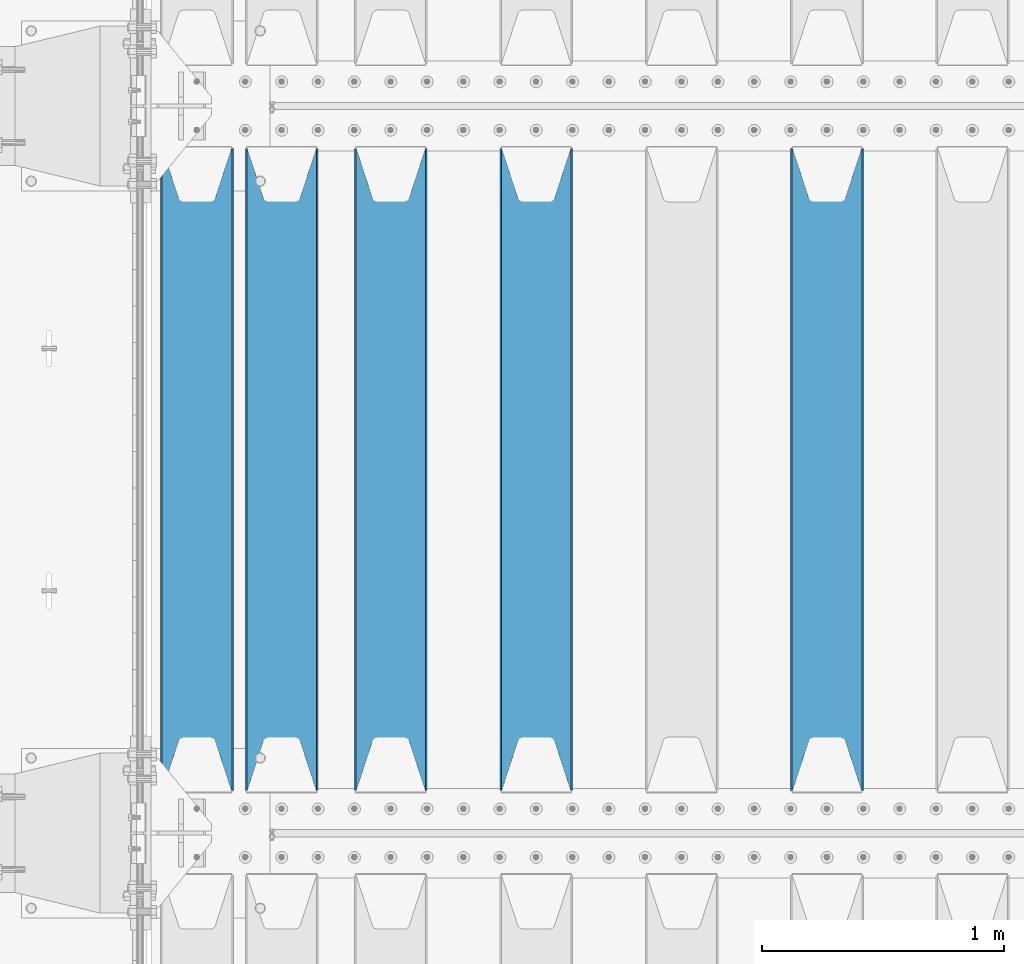
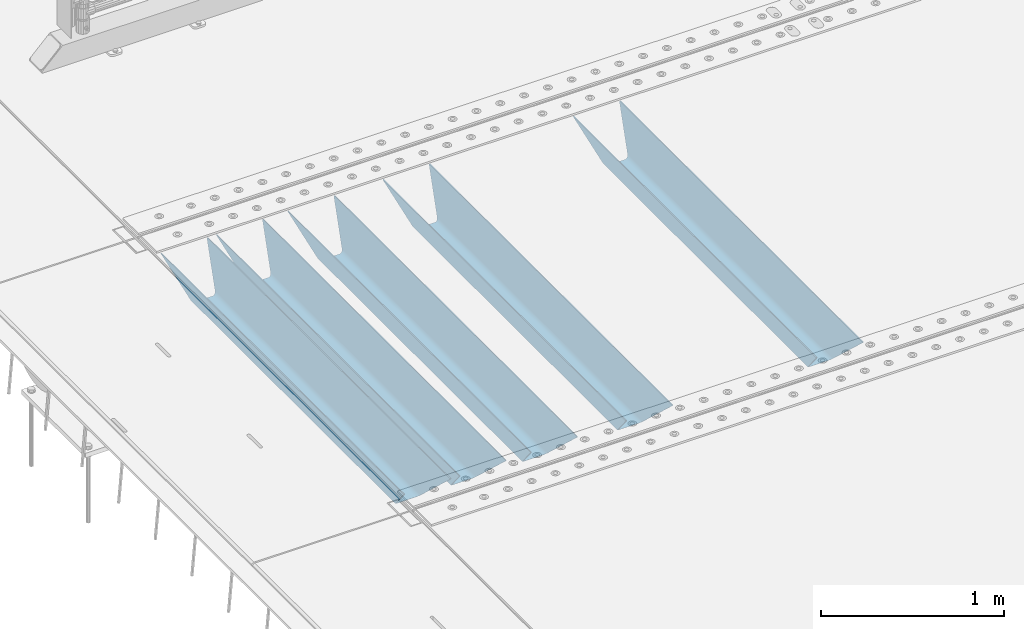
# One storey, part 112 of 240: 5 beams.
"""IFC2X3 building model written with IfcOpenShell, lengths in millimetres."""

from ifc_helpers import new_model, si_unit, frame, origin_with_axes, place, context, subcontext, project, spatial, faceted_brep, material, type_object, element, save


model = new_model("IFC2X3")

# Units and contexts
model_context = context("Model", 3, precision=1e-05, world=origin_with_axes())
body_context = subcontext(model_context, "Body", "Model", "MODEL_VIEW")
ifc_project = project(units=[si_unit("LENGTHUNIT", "METRE", prefix="MILLI"), si_unit("AREAUNIT", "SQUARE_METRE"), si_unit("VOLUMEUNIT", "CUBIC_METRE"), si_unit("MASSUNIT", "GRAM", prefix="KILO"), si_unit("TIMEUNIT", "SECOND"), si_unit("PLANEANGLEUNIT", "RADIAN"), si_unit("SOLIDANGLEUNIT", "STERADIAN"), si_unit("THERMODYNAMICTEMPERATUREUNIT", "DEGREE_CELSIUS"), si_unit("LUMINOUSINTENSITYUNIT", "LUMEN")], contexts=[model_context])

# Site, building, storey
site_placement = place(None, origin_with_axes())
site = spatial("IfcSite", under=ifc_project, at=site_placement, CompositionType="ELEMENT")
building_placement = place(site_placement, origin_with_axes())
building = spatial("IfcBuilding", under=site, at=building_placement, Name="Standard", CompositionType="ELEMENT")
storey_placement = place(building_placement, origin_with_axes())
storey = spatial("IfcBuildingStorey", under=building, at=storey_placement, Name="Undefined", CompositionType="ELEMENT", Elevation=0.0)

# Beams
ifc_material = material(Name="STEEL/S355N")
beam_type = type_object("IfcBeamType", PredefinedType="NOTDEFINED")
beam_1_placement = place(storey_placement, frame((45250.0, 30175.0, -115.0), z_axis=(0.0, 0.0, 1.0), x_axis=(0.0, 1.0, 0.0)))
element("IfcBeam", 1, at=beam_1_placement, inside=storey, type_object=beam_type, material=ifc_material, context=body_context, shape_type="Brep", body=[
    faceted_brep([(0.0, 150.0, 115.0), (0.0, 143.690000000002, 115.0), (2650.00000000297, 143.690000000002, 115.0), (2650.00000000297, 150.0, 115.0), (2650.00000000297, 142.059565218406, 110.000000003094), (2650.00000000297, 148.369565218403, 110.000000003094), (2441.90079219209, -80.1103600731149, -98.0992078077845), (2437.7588105432, -77.5672621345584, -102.241189456673), (2434.06523489747, -74.4080125315522, -105.934765102404), (2430.9108609509, -70.7102721255724, -109.089139048974), (2428.37322971128, -66.5649389910031, -111.626770288588), (2426.51472138055, -62.0739139532889, -113.485278619323), (2425.38102192092, -57.3475956567636, -114.618978078955), (2424.99999999987, -52.5021667386536, -115.0), (2424.99999999987, 52.5021667386536, -115.0), (2425.38102192092, 57.3475956567636, -114.618978078955), (2426.51472138055, 62.0739139532889, -113.485278619323), (2428.37322971128, 66.5649389910031, -111.626770288588), (2430.9108609509, 70.7102721255724, -109.089139048974), (2434.06523489747, 74.4080125315522, -105.934765102404), (2437.7588105432, 77.5672621345584, -102.241189456673), (2441.90079219209, 80.1103600731149, -98.0992078077846), (2446.38936140512, 81.9747917625791, -93.6106385947584), (2448.2494850041, 76.2713538057287, -91.7505149957729), (2444.62967112263, 74.76777986261, -95.3703288772456), (2441.28936334127, 72.7168944282894, -98.710636658607), (2438.31067330439, 70.1691124903809, -101.689326695487), (2435.76682334748, 67.1870637758839, -104.233176652398), (2433.72034654134, 63.8440531834931, -106.279653458539), (2432.22154950042, 60.2222587982324, -107.778450499454), (2431.30727574265, 56.4107117849126, -108.692724257221), (2430.99999999987, 52.5031078186876, -109.0), (2430.99999999987, -52.5031078186876, -109.0), (2431.30727574265, -56.4107117849126, -108.692724257221), (2432.22154950042, -60.2222587982324, -107.778450499454), (2433.72034654134, -63.8440531834931, -106.279653458539), (2435.76682334748, -67.1870637758839, -104.233176652398), (2438.31067330439, -70.1691124903809, -101.689326695487), (2441.28936334127, -72.7168944282894, -98.7106366586071), (2444.62967112263, -74.76777986261, -95.3703288772457), (2448.2494850041, -76.2713538057287, -91.7505149957729), (2650.00000000297, -142.059565218406, 110.000000003094), (2650.00000000297, -148.369565218403, 110.000000003094), (2446.38936140512, -81.9747917625791, -93.6106385947584), (2650.00000000297, -143.690000000002, 115.0), (2650.00000000297, -150.0, 115.0), (0.0, -143.690000000002, 115.0), (0.0, -150.0, 115.0), (0.0, -148.369565218258, 110.000000002667), (203.610638597427, -81.9747917625791, -93.6106385947584), (208.09920781045, -80.1103600731149, -98.0992078077845), (212.241189459342, -77.5672621345584, -102.241189456673), (215.93476510507, -74.4080125315522, -105.934765102404), (219.089139051641, -70.7102721255724, -109.089139048974), (221.626770291256, -66.5649389910031, -111.626770288588), (223.485278621989, -62.0739139532889, -113.485278619323), (224.618978081624, -57.3475956567636, -114.618978078955), (225.000000002663, -52.5021667386536, -115.0), (225.000000002663, 52.5021667386536, -115.0), (224.618978081624, 57.3475956567636, -114.618978078955), (223.485278621989, 62.0739139532889, -113.485278619323), (221.626770291256, 66.5649389910031, -111.626770288588), (219.089139051641, 70.7102721255724, -109.089139048974), (215.93476510507, 74.4080125315522, -105.934765102404), (212.241189459342, 77.5672621345584, -102.241189456673), (208.09920781045, 80.1103600731149, -98.0992078077846), (203.610638597427, 81.9747917625791, -93.6106385947584), (0.0, 148.369565218258, 110.000000002667), (0.0, 142.05956521826, 110.000000002667), (201.750514998439, 76.2713538057287, -91.7505149957729), (205.370328879908, 74.76777986261, -95.3703288772456), (208.710636661275, 72.7168944282894, -98.710636658607), (211.689326698153, 70.1691124903809, -101.689326695487), (214.233176655063, 67.1870637758839, -104.233176652398), (216.279653461206, 63.8440531834931, -106.279653458539), (217.778450502123, 60.2222587982324, -107.778450499454), (218.692724259887, 56.4107117849126, -108.692724257221), (219.000000002667, 52.5031078186876, -109.0), (219.000000002667, -52.5031078186876, -109.0), (218.692724259887, -56.4107117849126, -108.692724257221), (217.778450502123, -60.2222587982324, -107.778450499454), (216.279653461206, -63.8440531834931, -106.279653458539), (214.233176655063, -67.1870637758839, -104.233176652398), (211.689326698153, -70.1691124903809, -101.689326695487), (208.710636661275, -72.7168944282894, -98.7106366586071), (205.370328879915, -74.76777986261, -95.3703288772457), (201.750514998439, -76.2713538057287, -91.7505149957729), (0.0, -142.05956521826, 110.000000002667)], [[[0, 1, 2, 3]], [[3, 2, 4, 5]], [[6, 7, 8, 9, 10, 11, 12, 13, 14, 15, 16, 17, 18, 19, 20, 21, 22, 5, 4, 23, 24, 25, 26, 27, 28, 29, 30, 31, 32, 33, 34, 35, 36, 37, 38, 39, 40, 41, 42, 43]], [[44, 45, 42, 41]], [[46, 47, 45, 44]], [[43, 42, 45, 47, 48, 49]], [[6, 43, 49, 50]], [[7, 6, 50, 51]], [[8, 7, 51, 52]], [[9, 8, 52, 53]], [[10, 9, 53, 54]], [[11, 10, 54, 55]], [[12, 11, 55, 56]], [[13, 12, 56, 57]], [[14, 13, 57, 58]], [[15, 14, 58, 59]], [[16, 15, 59, 60]], [[17, 16, 60, 61]], [[18, 17, 61, 62]], [[19, 18, 62, 63]], [[20, 19, 63, 64]], [[21, 20, 64, 65]], [[22, 21, 65, 66]], [[0, 3, 5, 22, 66, 67]], [[1, 0, 67, 68]], [[23, 4, 2, 1, 68, 69]], [[24, 23, 69, 70]], [[25, 24, 70, 71]], [[26, 25, 71, 72]], [[27, 26, 72, 73]], [[28, 27, 73, 74]], [[29, 28, 74, 75]], [[30, 29, 75, 76]], [[31, 30, 76, 77]], [[32, 31, 77, 78]], [[33, 32, 78, 79]], [[34, 33, 79, 80]], [[35, 34, 80, 81]], [[36, 35, 81, 82]], [[37, 36, 82, 83]], [[38, 37, 83, 84]], [[39, 38, 84, 85]], [[40, 39, 85, 86]], [[46, 44, 41, 40, 86, 87]], [[47, 46, 87, 48]], [[86, 85, 84, 83, 82, 81, 80, 79, 78, 77, 76, 75, 74, 73, 72, 71, 70, 69, 68, 67, 66, 65, 64, 63, 62, 61, 60, 59, 58, 57, 56, 55, 54, 53, 52, 51, 50, 49, 48, 87]]]),
])
beam_2_placement = place(storey_placement, frame((44050.0, 30175.0, -115.0), z_axis=(0.0, 0.0, 1.0), x_axis=(0.0, 1.0, 0.0)))
element("IfcBeam", 2, at=beam_2_placement, inside=storey, type_object=beam_type, material=ifc_material, context=body_context, shape_type="Brep", body=[
    faceted_brep([(0.0, 150.0, 115.0), (0.0, 143.690000000002, 115.0), (2650.00000000297, 143.690000000002, 115.0), (2650.00000000297, 150.0, 115.0), (2650.00000000297, 142.059565218406, 110.000000003094), (2650.00000000297, 148.369565218403, 110.000000003094), (2441.90079219209, -80.1103600731149, -98.0992078077845), (2437.7588105432, -77.5672621345584, -102.241189456673), (2434.06523489747, -74.4080125315522, -105.934765102404), (2430.9108609509, -70.7102721255724, -109.089139048974), (2428.37322971128, -66.5649389910031, -111.626770288588), (2426.51472138055, -62.0739139532889, -113.485278619323), (2425.38102192092, -57.3475956567636, -114.618978078955), (2424.99999999987, -52.5021667386536, -115.0), (2424.99999999987, 52.5021667386536, -115.0), (2425.38102192092, 57.3475956567636, -114.618978078955), (2426.51472138055, 62.0739139532889, -113.485278619323), (2428.37322971128, 66.5649389910031, -111.626770288588), (2430.9108609509, 70.7102721255724, -109.089139048974), (2434.06523489747, 74.4080125315522, -105.934765102404), (2437.7588105432, 77.5672621345584, -102.241189456673), (2441.90079219209, 80.1103600731149, -98.0992078077846), (2446.38936140512, 81.9747917625791, -93.6106385947584), (2448.2494850041, 76.2713538057287, -91.7505149957729), (2444.62967112263, 74.76777986261, -95.3703288772456), (2441.28936334127, 72.7168944282894, -98.710636658607), (2438.31067330439, 70.1691124903809, -101.689326695487), (2435.76682334748, 67.1870637758839, -104.233176652398), (2433.72034654134, 63.8440531834931, -106.279653458539), (2432.22154950042, 60.2222587982324, -107.778450499454), (2431.30727574265, 56.4107117849126, -108.692724257221), (2430.99999999987, 52.5031078186876, -109.0), (2430.99999999987, -52.5031078186876, -109.0), (2431.30727574265, -56.4107117849126, -108.692724257221), (2432.22154950042, -60.2222587982324, -107.778450499454), (2433.72034654134, -63.8440531834931, -106.279653458539), (2435.76682334748, -67.1870637758839, -104.233176652398), (2438.31067330439, -70.1691124903809, -101.689326695487), (2441.28936334127, -72.7168944282894, -98.7106366586071), (2444.62967112263, -74.76777986261, -95.3703288772457), (2448.2494850041, -76.2713538057287, -91.7505149957729), (2650.00000000297, -142.059565218406, 110.000000003094), (2650.00000000297, -148.369565218403, 110.000000003094), (2446.38936140512, -81.9747917625791, -93.6106385947584), (2650.00000000297, -143.690000000002, 115.0), (2650.00000000297, -150.0, 115.0), (0.0, -143.690000000002, 115.0), (0.0, -150.0, 115.0), (0.0, -148.369565218258, 110.000000002667), (203.610638597427, -81.9747917625791, -93.6106385947584), (208.09920781045, -80.1103600731149, -98.0992078077845), (212.241189459342, -77.5672621345584, -102.241189456673), (215.93476510507, -74.4080125315522, -105.934765102404), (219.089139051641, -70.7102721255724, -109.089139048974), (221.626770291256, -66.5649389910031, -111.626770288588), (223.485278621989, -62.0739139532889, -113.485278619323), (224.618978081624, -57.3475956567636, -114.618978078955), (225.000000002663, -52.5021667386536, -115.0), (225.000000002663, 52.5021667386536, -115.0), (224.618978081624, 57.3475956567636, -114.618978078955), (223.485278621989, 62.0739139532889, -113.485278619323), (221.626770291256, 66.5649389910031, -111.626770288588), (219.089139051641, 70.7102721255724, -109.089139048974), (215.93476510507, 74.4080125315522, -105.934765102404), (212.241189459342, 77.5672621345584, -102.241189456673), (208.09920781045, 80.1103600731149, -98.0992078077846), (203.610638597427, 81.9747917625791, -93.6106385947584), (0.0, 148.369565218258, 110.000000002667), (0.0, 142.05956521826, 110.000000002667), (201.750514998439, 76.2713538057287, -91.7505149957729), (205.370328879908, 74.76777986261, -95.3703288772456), (208.710636661275, 72.7168944282894, -98.710636658607), (211.689326698153, 70.1691124903809, -101.689326695487), (214.233176655063, 67.1870637758839, -104.233176652398), (216.279653461206, 63.8440531834931, -106.279653458539), (217.778450502123, 60.2222587982324, -107.778450499454), (218.692724259887, 56.4107117849126, -108.692724257221), (219.000000002667, 52.5031078186876, -109.0), (219.000000002667, -52.5031078186876, -109.0), (218.692724259887, -56.4107117849126, -108.692724257221), (217.778450502123, -60.2222587982324, -107.778450499454), (216.279653461206, -63.8440531834931, -106.279653458539), (214.233176655063, -67.1870637758839, -104.233176652398), (211.689326698153, -70.1691124903809, -101.689326695487), (208.710636661275, -72.7168944282894, -98.7106366586071), (205.370328879915, -74.76777986261, -95.3703288772457), (201.750514998439, -76.2713538057287, -91.7505149957729), (0.0, -142.05956521826, 110.000000002667)], [[[0, 1, 2, 3]], [[3, 2, 4, 5]], [[6, 7, 8, 9, 10, 11, 12, 13, 14, 15, 16, 17, 18, 19, 20, 21, 22, 5, 4, 23, 24, 25, 26, 27, 28, 29, 30, 31, 32, 33, 34, 35, 36, 37, 38, 39, 40, 41, 42, 43]], [[44, 45, 42, 41]], [[46, 47, 45, 44]], [[43, 42, 45, 47, 48, 49]], [[6, 43, 49, 50]], [[7, 6, 50, 51]], [[8, 7, 51, 52]], [[9, 8, 52, 53]], [[10, 9, 53, 54]], [[11, 10, 54, 55]], [[12, 11, 55, 56]], [[13, 12, 56, 57]], [[14, 13, 57, 58]], [[15, 14, 58, 59]], [[16, 15, 59, 60]], [[17, 16, 60, 61]], [[18, 17, 61, 62]], [[19, 18, 62, 63]], [[20, 19, 63, 64]], [[21, 20, 64, 65]], [[22, 21, 65, 66]], [[0, 3, 5, 22, 66, 67]], [[1, 0, 67, 68]], [[23, 4, 2, 1, 68, 69]], [[24, 23, 69, 70]], [[25, 24, 70, 71]], [[26, 25, 71, 72]], [[27, 26, 72, 73]], [[28, 27, 73, 74]], [[29, 28, 74, 75]], [[30, 29, 75, 76]], [[31, 30, 76, 77]], [[32, 31, 77, 78]], [[33, 32, 78, 79]], [[34, 33, 79, 80]], [[35, 34, 80, 81]], [[36, 35, 81, 82]], [[37, 36, 82, 83]], [[38, 37, 83, 84]], [[39, 38, 84, 85]], [[40, 39, 85, 86]], [[46, 44, 41, 40, 86, 87]], [[47, 46, 87, 48]], [[86, 85, 84, 83, 82, 81, 80, 79, 78, 77, 76, 75, 74, 73, 72, 71, 70, 69, 68, 67, 66, 65, 64, 63, 62, 61, 60, 59, 58, 57, 56, 55, 54, 53, 52, 51, 50, 49, 48, 87]]]),
])
beam_3_placement = place(storey_placement, frame((43450.0, 30175.0, -115.0), z_axis=(0.0, 0.0, 1.0), x_axis=(0.0, 1.0, 0.0)))
element("IfcBeam", 3, at=beam_3_placement, inside=storey, type_object=beam_type, material=ifc_material, context=body_context, shape_type="Brep", body=[
    faceted_brep([(0.0, 150.0, 115.0), (0.0, 143.690000000002, 115.0), (2650.00000000297, 143.690000000002, 115.0), (2650.00000000297, 150.0, 115.0), (2650.00000000297, 142.059565218406, 110.000000003094), (2650.00000000297, 148.369565218403, 110.000000003094), (2441.90079219209, -80.1103600731149, -98.0992078077845), (2437.7588105432, -77.5672621345584, -102.241189456673), (2434.06523489747, -74.4080125315522, -105.934765102404), (2430.9108609509, -70.7102721255724, -109.089139048974), (2428.37322971128, -66.5649389910031, -111.626770288588), (2426.51472138055, -62.0739139532889, -113.485278619323), (2425.38102192092, -57.3475956567636, -114.618978078955), (2424.99999999987, -52.5021667386536, -115.0), (2424.99999999987, 52.5021667386536, -115.0), (2425.38102192092, 57.3475956567636, -114.618978078955), (2426.51472138055, 62.0739139532889, -113.485278619323), (2428.37322971128, 66.5649389910031, -111.626770288588), (2430.9108609509, 70.7102721255724, -109.089139048974), (2434.06523489747, 74.4080125315522, -105.934765102404), (2437.7588105432, 77.5672621345584, -102.241189456673), (2441.90079219209, 80.1103600731149, -98.0992078077846), (2446.38936140512, 81.9747917625791, -93.6106385947584), (2448.2494850041, 76.2713538057287, -91.7505149957729), (2444.62967112263, 74.76777986261, -95.3703288772456), (2441.28936334127, 72.7168944282894, -98.710636658607), (2438.31067330439, 70.1691124903809, -101.689326695487), (2435.76682334748, 67.1870637758839, -104.233176652398), (2433.72034654134, 63.8440531834931, -106.279653458539), (2432.22154950042, 60.2222587982324, -107.778450499454), (2431.30727574265, 56.4107117849126, -108.692724257221), (2430.99999999987, 52.5031078186876, -109.0), (2430.99999999987, -52.5031078186876, -109.0), (2431.30727574265, -56.4107117849126, -108.692724257221), (2432.22154950042, -60.2222587982324, -107.778450499454), (2433.72034654134, -63.8440531834931, -106.279653458539), (2435.76682334748, -67.1870637758839, -104.233176652398), (2438.31067330439, -70.1691124903809, -101.689326695487), (2441.28936334127, -72.7168944282894, -98.7106366586071), (2444.62967112263, -74.76777986261, -95.3703288772457), (2448.2494850041, -76.2713538057287, -91.7505149957729), (2650.00000000297, -142.059565218406, 110.000000003094), (2650.00000000297, -148.369565218403, 110.000000003094), (2446.38936140512, -81.9747917625791, -93.6106385947584), (2650.00000000297, -143.690000000002, 115.0), (2650.00000000297, -150.0, 115.0), (0.0, -143.690000000002, 115.0), (0.0, -150.0, 115.0), (0.0, -148.369565218258, 110.000000002667), (203.610638597427, -81.9747917625791, -93.6106385947584), (208.09920781045, -80.1103600731149, -98.0992078077845), (212.241189459342, -77.5672621345584, -102.241189456673), (215.93476510507, -74.4080125315522, -105.934765102404), (219.089139051641, -70.7102721255724, -109.089139048974), (221.626770291256, -66.5649389910031, -111.626770288588), (223.485278621989, -62.0739139532889, -113.485278619323), (224.618978081624, -57.3475956567636, -114.618978078955), (225.000000002663, -52.5021667386536, -115.0), (225.000000002663, 52.5021667386536, -115.0), (224.618978081624, 57.3475956567636, -114.618978078955), (223.485278621989, 62.0739139532889, -113.485278619323), (221.626770291256, 66.5649389910031, -111.626770288588), (219.089139051641, 70.7102721255724, -109.089139048974), (215.93476510507, 74.4080125315522, -105.934765102404), (212.241189459342, 77.5672621345584, -102.241189456673), (208.09920781045, 80.1103600731149, -98.0992078077846), (203.610638597427, 81.9747917625791, -93.6106385947584), (0.0, 148.369565218258, 110.000000002667), (0.0, 142.05956521826, 110.000000002667), (201.750514998439, 76.2713538057287, -91.7505149957729), (205.370328879908, 74.76777986261, -95.3703288772456), (208.710636661275, 72.7168944282894, -98.710636658607), (211.689326698153, 70.1691124903809, -101.689326695487), (214.233176655063, 67.1870637758839, -104.233176652398), (216.279653461206, 63.8440531834931, -106.279653458539), (217.778450502123, 60.2222587982324, -107.778450499454), (218.692724259887, 56.4107117849126, -108.692724257221), (219.000000002667, 52.5031078186876, -109.0), (219.000000002667, -52.5031078186876, -109.0), (218.692724259887, -56.4107117849126, -108.692724257221), (217.778450502123, -60.2222587982324, -107.778450499454), (216.279653461206, -63.8440531834931, -106.279653458539), (214.233176655063, -67.1870637758839, -104.233176652398), (211.689326698153, -70.1691124903809, -101.689326695487), (208.710636661275, -72.7168944282894, -98.7106366586071), (205.370328879915, -74.76777986261, -95.3703288772457), (201.750514998439, -76.2713538057287, -91.7505149957729), (0.0, -142.05956521826, 110.000000002667)], [[[0, 1, 2, 3]], [[3, 2, 4, 5]], [[6, 7, 8, 9, 10, 11, 12, 13, 14, 15, 16, 17, 18, 19, 20, 21, 22, 5, 4, 23, 24, 25, 26, 27, 28, 29, 30, 31, 32, 33, 34, 35, 36, 37, 38, 39, 40, 41, 42, 43]], [[44, 45, 42, 41]], [[46, 47, 45, 44]], [[43, 42, 45, 47, 48, 49]], [[6, 43, 49, 50]], [[7, 6, 50, 51]], [[8, 7, 51, 52]], [[9, 8, 52, 53]], [[10, 9, 53, 54]], [[11, 10, 54, 55]], [[12, 11, 55, 56]], [[13, 12, 56, 57]], [[14, 13, 57, 58]], [[15, 14, 58, 59]], [[16, 15, 59, 60]], [[17, 16, 60, 61]], [[18, 17, 61, 62]], [[19, 18, 62, 63]], [[20, 19, 63, 64]], [[21, 20, 64, 65]], [[22, 21, 65, 66]], [[0, 3, 5, 22, 66, 67]], [[1, 0, 67, 68]], [[23, 4, 2, 1, 68, 69]], [[24, 23, 69, 70]], [[25, 24, 70, 71]], [[26, 25, 71, 72]], [[27, 26, 72, 73]], [[28, 27, 73, 74]], [[29, 28, 74, 75]], [[30, 29, 75, 76]], [[31, 30, 76, 77]], [[32, 31, 77, 78]], [[33, 32, 78, 79]], [[34, 33, 79, 80]], [[35, 34, 80, 81]], [[36, 35, 81, 82]], [[37, 36, 82, 83]], [[38, 37, 83, 84]], [[39, 38, 84, 85]], [[40, 39, 85, 86]], [[46, 44, 41, 40, 86, 87]], [[47, 46, 87, 48]], [[86, 85, 84, 83, 82, 81, 80, 79, 78, 77, 76, 75, 74, 73, 72, 71, 70, 69, 68, 67, 66, 65, 64, 63, 62, 61, 60, 59, 58, 57, 56, 55, 54, 53, 52, 51, 50, 49, 48, 87]]]),
])
beam_4_placement = place(storey_placement, frame((43000.0, 30175.0, -115.0), z_axis=(0.0, 0.0, 1.0), x_axis=(0.0, 1.0, 0.0)))
element("IfcBeam", 4, at=beam_4_placement, inside=storey, type_object=beam_type, material=ifc_material, context=body_context, shape_type="Brep", body=[
    faceted_brep([(0.0, 150.0, 115.0), (0.0, 143.690000000002, 115.0), (2650.00000000297, 143.690000000002, 115.0), (2650.00000000297, 150.0, 115.0), (2650.00000000297, 142.059565218406, 110.000000003094), (2650.00000000297, 148.369565218403, 110.000000003094), (2441.90079219209, -80.1103600731149, -98.0992078077845), (2437.7588105432, -77.5672621345584, -102.241189456673), (2434.06523489747, -74.4080125315522, -105.934765102404), (2430.9108609509, -70.7102721255724, -109.089139048974), (2428.37322971128, -66.5649389910031, -111.626770288588), (2426.51472138055, -62.0739139532889, -113.485278619323), (2425.38102192092, -57.3475956567636, -114.618978078955), (2424.99999999987, -52.5021667386536, -115.0), (2424.99999999987, 52.5021667386536, -115.0), (2425.38102192092, 57.3475956567636, -114.618978078955), (2426.51472138055, 62.0739139532889, -113.485278619323), (2428.37322971128, 66.5649389910031, -111.626770288588), (2430.9108609509, 70.7102721255724, -109.089139048974), (2434.06523489747, 74.4080125315522, -105.934765102404), (2437.7588105432, 77.5672621345584, -102.241189456673), (2441.90079219209, 80.1103600731149, -98.0992078077846), (2446.38936140512, 81.9747917625791, -93.6106385947584), (2448.2494850041, 76.2713538057287, -91.7505149957729), (2444.62967112263, 74.76777986261, -95.3703288772456), (2441.28936334127, 72.7168944282894, -98.710636658607), (2438.31067330439, 70.1691124903809, -101.689326695487), (2435.76682334748, 67.1870637758839, -104.233176652398), (2433.72034654134, 63.8440531834931, -106.279653458539), (2432.22154950042, 60.2222587982324, -107.778450499454), (2431.30727574265, 56.4107117849126, -108.692724257221), (2430.99999999987, 52.5031078186876, -109.0), (2430.99999999987, -52.5031078186876, -109.0), (2431.30727574265, -56.4107117849126, -108.692724257221), (2432.22154950042, -60.2222587982324, -107.778450499454), (2433.72034654134, -63.8440531834931, -106.279653458539), (2435.76682334748, -67.1870637758839, -104.233176652398), (2438.31067330439, -70.1691124903809, -101.689326695487), (2441.28936334127, -72.7168944282894, -98.7106366586071), (2444.62967112263, -74.76777986261, -95.3703288772457), (2448.2494850041, -76.2713538057287, -91.7505149957729), (2650.00000000297, -142.059565218406, 110.000000003094), (2650.00000000297, -148.369565218403, 110.000000003094), (2446.38936140512, -81.9747917625791, -93.6106385947584), (2650.00000000297, -143.690000000002, 115.0), (2650.00000000297, -150.0, 115.0), (0.0, -143.690000000002, 115.0), (0.0, -150.0, 115.0), (0.0, -148.369565218258, 110.000000002667), (203.610638597427, -81.9747917625791, -93.6106385947584), (208.09920781045, -80.1103600731149, -98.0992078077845), (212.241189459342, -77.5672621345584, -102.241189456673), (215.93476510507, -74.4080125315522, -105.934765102404), (219.089139051641, -70.7102721255724, -109.089139048974), (221.626770291256, -66.5649389910031, -111.626770288588), (223.485278621989, -62.0739139532889, -113.485278619323), (224.618978081624, -57.3475956567636, -114.618978078955), (225.000000002663, -52.5021667386536, -115.0), (225.000000002663, 52.5021667386536, -115.0), (224.618978081624, 57.3475956567636, -114.618978078955), (223.485278621989, 62.0739139532889, -113.485278619323), (221.626770291256, 66.5649389910031, -111.626770288588), (219.089139051641, 70.7102721255724, -109.089139048974), (215.93476510507, 74.4080125315522, -105.934765102404), (212.241189459342, 77.5672621345584, -102.241189456673), (208.09920781045, 80.1103600731149, -98.0992078077846), (203.610638597427, 81.9747917625791, -93.6106385947584), (0.0, 148.369565218258, 110.000000002667), (0.0, 142.05956521826, 110.000000002667), (201.750514998439, 76.2713538057287, -91.7505149957729), (205.370328879908, 74.76777986261, -95.3703288772456), (208.710636661275, 72.7168944282894, -98.710636658607), (211.689326698153, 70.1691124903809, -101.689326695487), (214.233176655063, 67.1870637758839, -104.233176652398), (216.279653461206, 63.8440531834931, -106.279653458539), (217.778450502123, 60.2222587982324, -107.778450499454), (218.692724259887, 56.4107117849126, -108.692724257221), (219.000000002667, 52.5031078186876, -109.0), (219.000000002667, -52.5031078186876, -109.0), (218.692724259887, -56.4107117849126, -108.692724257221), (217.778450502123, -60.2222587982324, -107.778450499454), (216.279653461206, -63.8440531834931, -106.279653458539), (214.233176655063, -67.1870637758839, -104.233176652398), (211.689326698153, -70.1691124903809, -101.689326695487), (208.710636661275, -72.7168944282894, -98.7106366586071), (205.370328879915, -74.76777986261, -95.3703288772457), (201.750514998439, -76.2713538057287, -91.7505149957729), (0.0, -142.05956521826, 110.000000002667)], [[[0, 1, 2, 3]], [[3, 2, 4, 5]], [[6, 7, 8, 9, 10, 11, 12, 13, 14, 15, 16, 17, 18, 19, 20, 21, 22, 5, 4, 23, 24, 25, 26, 27, 28, 29, 30, 31, 32, 33, 34, 35, 36, 37, 38, 39, 40, 41, 42, 43]], [[44, 45, 42, 41]], [[46, 47, 45, 44]], [[43, 42, 45, 47, 48, 49]], [[6, 43, 49, 50]], [[7, 6, 50, 51]], [[8, 7, 51, 52]], [[9, 8, 52, 53]], [[10, 9, 53, 54]], [[11, 10, 54, 55]], [[12, 11, 55, 56]], [[13, 12, 56, 57]], [[14, 13, 57, 58]], [[15, 14, 58, 59]], [[16, 15, 59, 60]], [[17, 16, 60, 61]], [[18, 17, 61, 62]], [[19, 18, 62, 63]], [[20, 19, 63, 64]], [[21, 20, 64, 65]], [[22, 21, 65, 66]], [[0, 3, 5, 22, 66, 67]], [[1, 0, 67, 68]], [[23, 4, 2, 1, 68, 69]], [[24, 23, 69, 70]], [[25, 24, 70, 71]], [[26, 25, 71, 72]], [[27, 26, 72, 73]], [[28, 27, 73, 74]], [[29, 28, 74, 75]], [[30, 29, 75, 76]], [[31, 30, 76, 77]], [[32, 31, 77, 78]], [[33, 32, 78, 79]], [[34, 33, 79, 80]], [[35, 34, 80, 81]], [[36, 35, 81, 82]], [[37, 36, 82, 83]], [[38, 37, 83, 84]], [[39, 38, 84, 85]], [[40, 39, 85, 86]], [[46, 44, 41, 40, 86, 87]], [[47, 46, 87, 48]], [[86, 85, 84, 83, 82, 81, 80, 79, 78, 77, 76, 75, 74, 73, 72, 71, 70, 69, 68, 67, 66, 65, 64, 63, 62, 61, 60, 59, 58, 57, 56, 55, 54, 53, 52, 51, 50, 49, 48, 87]]]),
])
beam_5_placement = place(storey_placement, frame((42650.0, 30175.0, -115.0), z_axis=(0.0, 0.0, 1.0), x_axis=(0.0, 1.0, 0.0)))
element("IfcBeam", 5, at=beam_5_placement, inside=storey, type_object=beam_type, material=ifc_material, context=body_context, shape_type="Brep", body=[
    faceted_brep([(0.0, 150.0, 115.0), (0.0, 143.690000000002, 115.0), (2650.00000000297, 143.690000000002, 115.0), (2650.00000000297, 150.0, 115.0), (2650.00000000297, 142.059565218406, 110.000000003094), (2650.00000000297, 148.369565218403, 110.000000003094), (2441.90079219209, -80.1103600731149, -98.0992078077845), (2437.7588105432, -77.5672621345584, -102.241189456673), (2434.06523489747, -74.4080125315522, -105.934765102404), (2430.9108609509, -70.7102721255724, -109.089139048974), (2428.37322971128, -66.5649389910031, -111.626770288588), (2426.51472138055, -62.0739139532889, -113.485278619323), (2425.38102192092, -57.3475956567636, -114.618978078955), (2424.99999999987, -52.5021667386536, -115.0), (2424.99999999987, 52.5021667386536, -115.0), (2425.38102192092, 57.3475956567636, -114.618978078955), (2426.51472138055, 62.0739139532889, -113.485278619323), (2428.37322971128, 66.5649389910031, -111.626770288588), (2430.9108609509, 70.7102721255724, -109.089139048974), (2434.06523489747, 74.4080125315522, -105.934765102404), (2437.7588105432, 77.5672621345584, -102.241189456673), (2441.90079219209, 80.1103600731149, -98.0992078077846), (2446.38936140512, 81.9747917625791, -93.6106385947584), (2448.2494850041, 76.2713538057287, -91.7505149957729), (2444.62967112263, 74.76777986261, -95.3703288772456), (2441.28936334127, 72.7168944282894, -98.710636658607), (2438.31067330439, 70.1691124903809, -101.689326695487), (2435.76682334748, 67.1870637758839, -104.233176652398), (2433.72034654134, 63.8440531834931, -106.279653458539), (2432.22154950042, 60.2222587982324, -107.778450499454), (2431.30727574265, 56.4107117849126, -108.692724257221), (2430.99999999987, 52.5031078186876, -109.0), (2430.99999999987, -52.5031078186876, -109.0), (2431.30727574265, -56.4107117849126, -108.692724257221), (2432.22154950042, -60.2222587982324, -107.778450499454), (2433.72034654134, -63.8440531834931, -106.279653458539), (2435.76682334748, -67.1870637758839, -104.233176652398), (2438.31067330439, -70.1691124903809, -101.689326695487), (2441.28936334127, -72.7168944282894, -98.7106366586071), (2444.62967112263, -74.76777986261, -95.3703288772457), (2448.2494850041, -76.2713538057287, -91.7505149957729), (2650.00000000297, -142.059565218406, 110.000000003094), (2650.00000000297, -148.369565218403, 110.000000003094), (2446.38936140512, -81.9747917625791, -93.6106385947584), (2650.00000000297, -143.690000000002, 115.0), (2650.00000000297, -150.0, 115.0), (0.0, -143.690000000002, 115.0), (0.0, -150.0, 115.0), (0.0, -148.369565218258, 110.000000002667), (203.610638597427, -81.9747917625791, -93.6106385947584), (208.09920781045, -80.1103600731149, -98.0992078077845), (212.241189459342, -77.5672621345584, -102.241189456673), (215.93476510507, -74.4080125315522, -105.934765102404), (219.089139051641, -70.7102721255724, -109.089139048974), (221.626770291256, -66.5649389910031, -111.626770288588), (223.485278621989, -62.0739139532889, -113.485278619323), (224.618978081624, -57.3475956567636, -114.618978078955), (225.000000002663, -52.5021667386536, -115.0), (225.000000002663, 52.5021667386536, -115.0), (224.618978081624, 57.3475956567636, -114.618978078955), (223.485278621989, 62.0739139532889, -113.485278619323), (221.626770291256, 66.5649389910031, -111.626770288588), (219.089139051641, 70.7102721255724, -109.089139048974), (215.93476510507, 74.4080125315522, -105.934765102404), (212.241189459342, 77.5672621345584, -102.241189456673), (208.09920781045, 80.1103600731149, -98.0992078077846), (203.610638597427, 81.9747917625791, -93.6106385947584), (0.0, 148.369565218258, 110.000000002667), (0.0, 142.05956521826, 110.000000002667), (201.750514998439, 76.2713538057287, -91.7505149957729), (205.370328879908, 74.76777986261, -95.3703288772456), (208.710636661275, 72.7168944282894, -98.710636658607), (211.689326698153, 70.1691124903809, -101.689326695487), (214.233176655063, 67.1870637758839, -104.233176652398), (216.279653461206, 63.8440531834931, -106.279653458539), (217.778450502123, 60.2222587982324, -107.778450499454), (218.692724259887, 56.4107117849126, -108.692724257221), (219.000000002667, 52.5031078186876, -109.0), (219.000000002667, -52.5031078186876, -109.0), (218.692724259887, -56.4107117849126, -108.692724257221), (217.778450502123, -60.2222587982324, -107.778450499454), (216.279653461206, -63.8440531834931, -106.279653458539), (214.233176655063, -67.1870637758839, -104.233176652398), (211.689326698153, -70.1691124903809, -101.689326695487), (208.710636661275, -72.7168944282894, -98.7106366586071), (205.370328879915, -74.76777986261, -95.3703288772457), (201.750514998439, -76.2713538057287, -91.7505149957729), (0.0, -142.05956521826, 110.000000002667)], [[[0, 1, 2, 3]], [[3, 2, 4, 5]], [[6, 7, 8, 9, 10, 11, 12, 13, 14, 15, 16, 17, 18, 19, 20, 21, 22, 5, 4, 23, 24, 25, 26, 27, 28, 29, 30, 31, 32, 33, 34, 35, 36, 37, 38, 39, 40, 41, 42, 43]], [[44, 45, 42, 41]], [[46, 47, 45, 44]], [[43, 42, 45, 47, 48, 49]], [[6, 43, 49, 50]], [[7, 6, 50, 51]], [[8, 7, 51, 52]], [[9, 8, 52, 53]], [[10, 9, 53, 54]], [[11, 10, 54, 55]], [[12, 11, 55, 56]], [[13, 12, 56, 57]], [[14, 13, 57, 58]], [[15, 14, 58, 59]], [[16, 15, 59, 60]], [[17, 16, 60, 61]], [[18, 17, 61, 62]], [[19, 18, 62, 63]], [[20, 19, 63, 64]], [[21, 20, 64, 65]], [[22, 21, 65, 66]], [[0, 3, 5, 22, 66, 67]], [[1, 0, 67, 68]], [[23, 4, 2, 1, 68, 69]], [[24, 23, 69, 70]], [[25, 24, 70, 71]], [[26, 25, 71, 72]], [[27, 26, 72, 73]], [[28, 27, 73, 74]], [[29, 28, 74, 75]], [[30, 29, 75, 76]], [[31, 30, 76, 77]], [[32, 31, 77, 78]], [[33, 32, 78, 79]], [[34, 33, 79, 80]], [[35, 34, 80, 81]], [[36, 35, 81, 82]], [[37, 36, 82, 83]], [[38, 37, 83, 84]], [[39, 38, 84, 85]], [[40, 39, 85, 86]], [[46, 44, 41, 40, 86, 87]], [[47, 46, 87, 48]], [[86, 85, 84, 83, 82, 81, 80, 79, 78, 77, 76, 75, 74, 73, 72, 71, 70, 69, 68, 67, 66, 65, 64, 63, 62, 61, 60, 59, 58, 57, 56, 55, 54, 53, 52, 51, 50, 49, 48, 87]]]),
])

save(model, "model.ifc")
